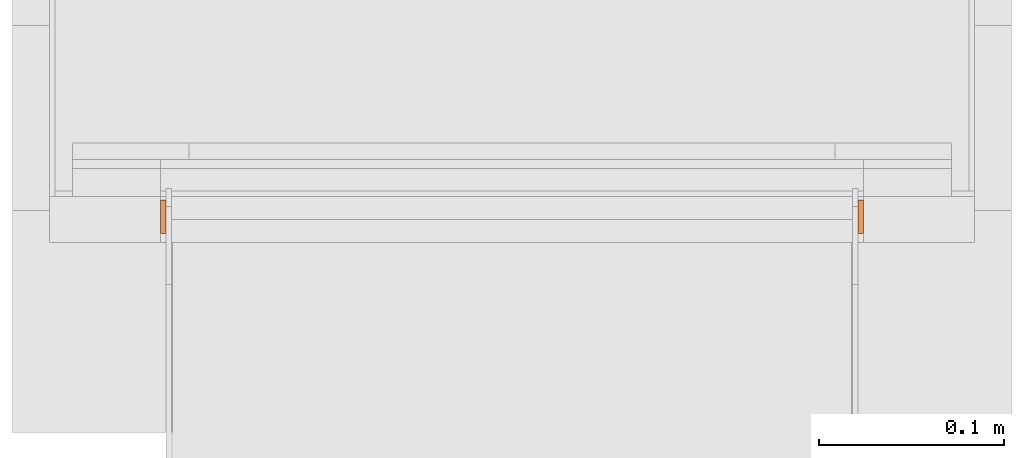
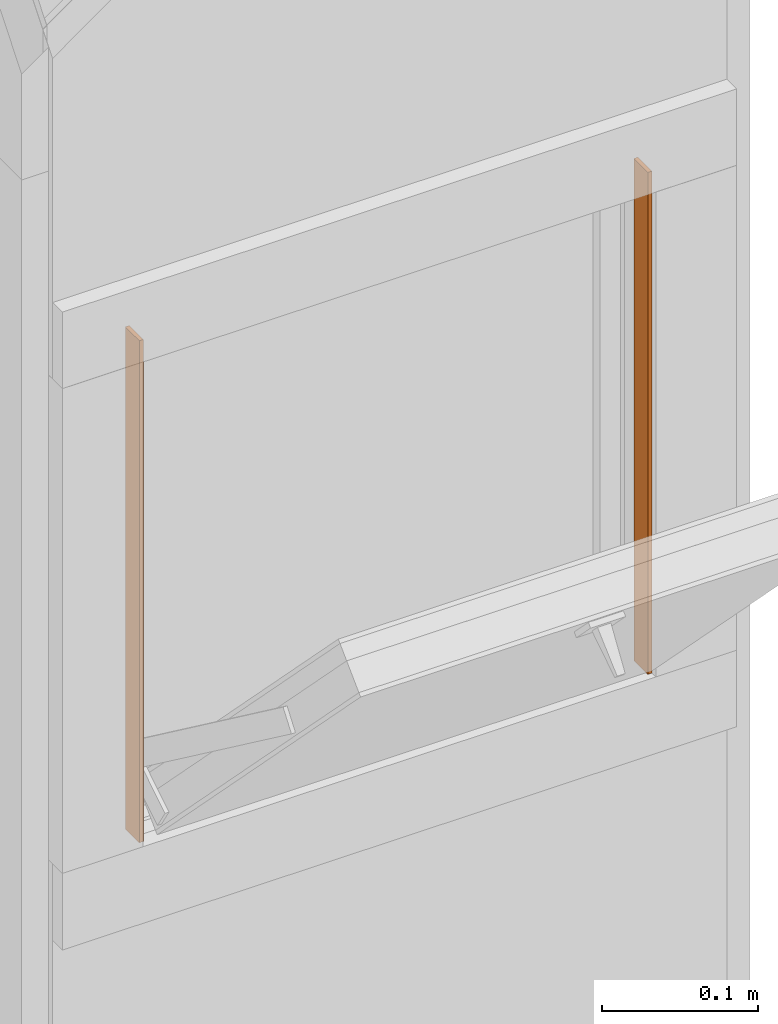
# One storey, part 2 of 4: 2 proxies.
"""IFC2X3 building model written with IfcOpenShell, lengths in metres."""

from ifc_helpers import new_model, entity, si_unit, converted_unit, derived_unit, money_unit, direction, frame, origin_with_axes, place, context, subcontext, project, spatial, polyline, outline, extrude, material, type_object, element, save


model = new_model("IFC2X3")

# Units and contexts
model_context = context("Model", 3, precision=1e-05, world=origin_with_axes(), true_north=direction((0.0, 1.0)))
plan_context = context("Plan", 3, precision=1e-05, world=origin_with_axes(), true_north=direction((0.0, 1.0)))
body_context = subcontext(model_context, "Body", "Model", "MODEL_VIEW")
ifc_project = project(units=[si_unit("LENGTHUNIT", "METRE"), si_unit("AREAUNIT", "SQUARE_METRE"), si_unit("VOLUMEUNIT", "CUBIC_METRE"), converted_unit("PLANEANGLEUNIT", "DEGREE", entity("IfcPlaneAngleMeasure", 0.0174532925199), si_unit("PLANEANGLEUNIT", "RADIAN"), dimensions=[0, 0, 0, 0, 0, 0, 0]), si_unit("SOLIDANGLEUNIT", "STERADIAN"), money_unit("CHF"), converted_unit("TIMEUNIT", "Year", entity("IfcTimeMeasure", 31556926.0), si_unit("TIMEUNIT", "SECOND"), dimensions=[0, 0, 1, 0, 0, 0, 0]), si_unit("MASSUNIT", "GRAM", prefix="KILO"), si_unit("THERMODYNAMICTEMPERATUREUNIT", "DEGREE_CELSIUS"), si_unit("LUMINOUSINTENSITYUNIT", "LUMEN"), si_unit("ENERGYUNIT", "JOULE", prefix="MEGA"), derived_unit("THERMALCONDUCTANCEUNIT", [(si_unit("POWERUNIT", "WATT"), 1), (si_unit("LENGTHUNIT", "METRE"), -1), (si_unit("THERMODYNAMICTEMPERATUREUNIT", "KELVIN"), -1)]), derived_unit("SPECIFICHEATCAPACITYUNIT", [(si_unit("ENERGYUNIT", "JOULE"), 1), (si_unit("MASSUNIT", "GRAM", prefix="KILO"), -1), (si_unit("THERMODYNAMICTEMPERATUREUNIT", "KELVIN"), -1)]), derived_unit("MASSDENSITYUNIT", [(si_unit("MASSUNIT", "GRAM", prefix="KILO"), 1), (si_unit("VOLUMEUNIT", "CUBIC_METRE"), -1)])], contexts=[model_context, plan_context])

# Site, building, storey
site_placement = place(None, origin_with_axes())
site = spatial("IfcSite", under=ifc_project, at=site_placement, CompositionType="ELEMENT")
building_placement = place(site_placement, origin_with_axes())
building = spatial("IfcBuilding", under=site, at=building_placement, CompositionType="ELEMENT")
storey_placement = place(building_placement, origin_with_axes())
storey = spatial("IfcBuildingStorey", under=building, at=storey_placement, Name="EG00", CompositionType="ELEMENT", Elevation=0.0)

# Proxies
ifc_material = material(Name="Metall, Aluminium")
building_element_proxy_type = type_object("IfcBuildingElementProxyType", Name="Metall, Aluminium 3", PredefinedType="NOTDEFINED")
proxy_1_placement = place(storey_placement, frame((1.99655524907, -8.22943070606, 0.61), z_axis=(0.0, 0.0, 1.0), x_axis=(0.0, -1.0, 0.0)))
element("IfcBuildingElementProxy", 1, at=proxy_1_placement, inside=storey, type_object=building_element_proxy_type, material=ifc_material, Name="Wand-006", context=body_context, shape_type="SweptSolid", body=[
    extrude(outline(polyline([(0.0, -0.003), (0.018, -0.003), (0.018, 0.0), (0.0, 0.0), (0.0, -0.003)])), origin_with_axes(), (0.0, 0.0, 1.0), 0.393521144674),
])
proxy_2_placement = place(storey_placement, frame((1.61655524907, -8.22943070606, 0.61), z_axis=(0.0, 0.0, 1.0), x_axis=(0.0, -1.0, 0.0)))
element("IfcBuildingElementProxy", 2, at=proxy_2_placement, inside=storey, type_object=building_element_proxy_type, material=ifc_material, Name="Wand-006", context=body_context, shape_type="SweptSolid", body=[
    extrude(outline(polyline([(0.0, 0.0), (0.018, 0.0), (0.018, 0.003), (0.0, 0.003), (0.0, 0.0)])), origin_with_axes(), (0.0, 0.0, 1.0), 0.393521144674),
])

save(model, "model.ifc")
